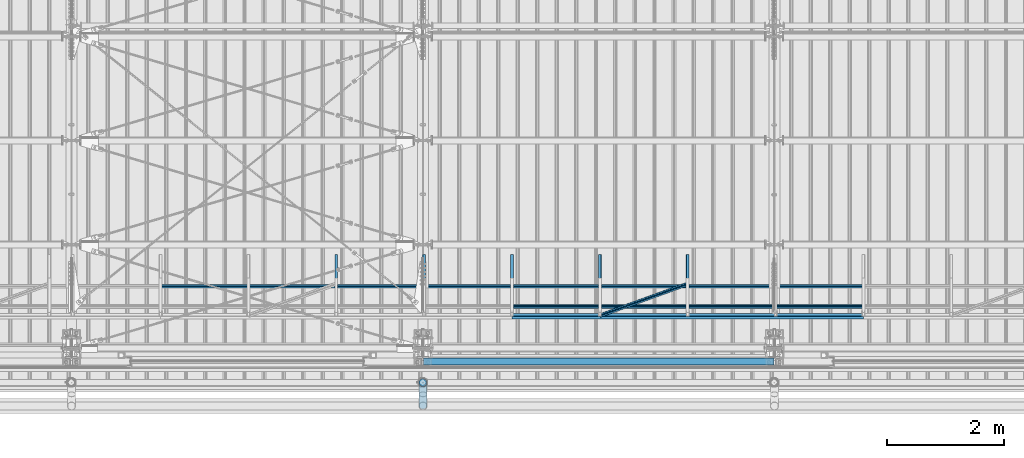
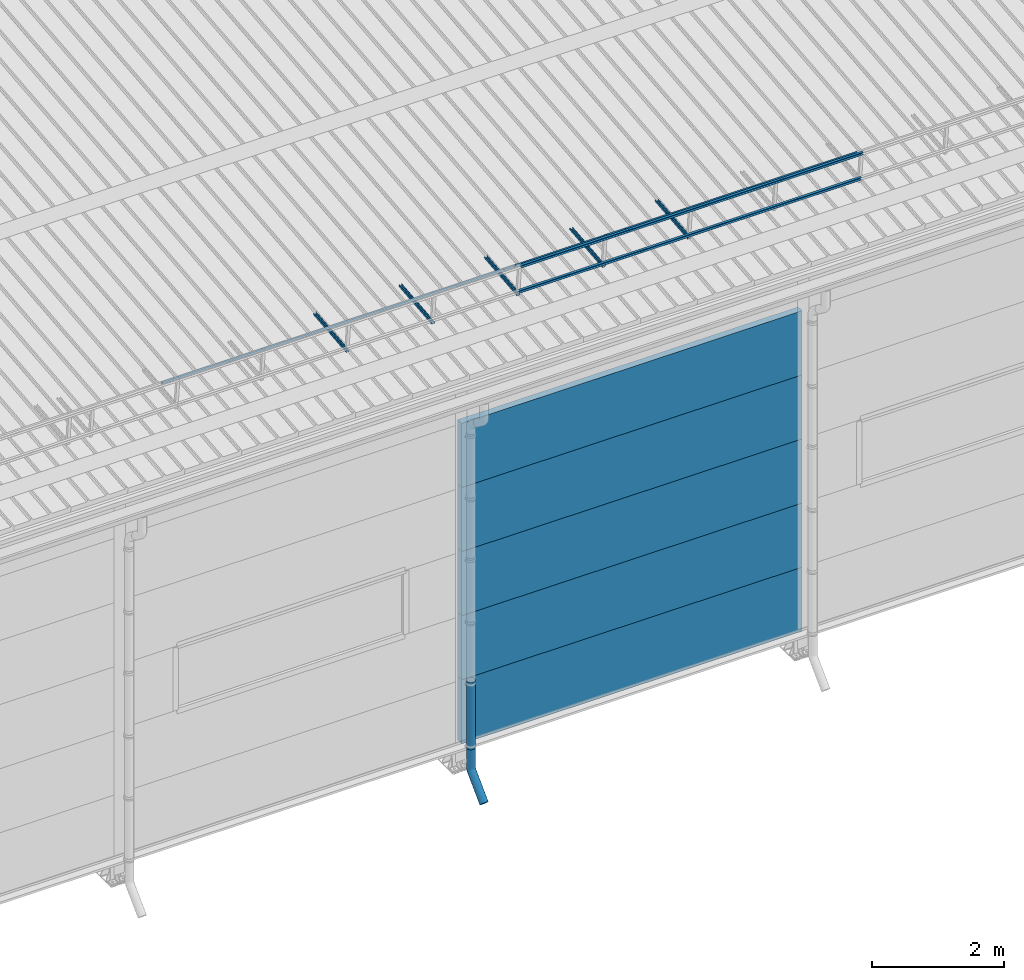
# One storey, part 37 of 709: 18 beams, 18 elements without a shape of their own.
"""IFC4 building model written with IfcOpenShell, lengths in millimetres."""

import ifcopenshell
import ifcopenshell.guid

model = None  # the IFC model being written
_history = None  # IfcOwnerHistory: only IFC2X3 demands one
_inside = {}  # id of a spatial element -> (the spatial element, [elements in it])
_under = {}  # id of a project, library or spatial element -> (it, [spatial elements below it])
_declared = {}  # id of a project -> (the project, [libraries it declares])
_typed = {}  # id of a type object -> (the type object, [elements of that type])
_made_of = {}  # id of a material, layer set ... -> (it, [elements and type objects made of it])


def new_model(schema):
    """Start an empty IFC model of exactly this schema.

    Asked for "IFC4X3", IfcOpenShell would pick the latest addendum, in which some entities
    have other attributes; the version numbers below select the first issue.
    IFC2X3 requires an IfcOwnerHistory on every rooted entity: one is made here for all.
    """
    global model, _history
    if schema == "IFC4X3":
        model = ifcopenshell.file(schema_version=(4, 3, 0, 0))
    else:
        model = ifcopenshell.file(schema=schema)
    _inside.clear()
    _under.clear()
    _declared.clear()
    _typed.clear()
    _made_of.clear()
    _history = None
    if model.schema == "IFC2X3":
        org = make("IfcOrganization", Name="unknown")
        user = make(
            "IfcPersonAndOrganization",
            ThePerson=make("IfcPerson", FamilyName="unknown"),
            TheOrganization=org,
        )
        app = make(
            "IfcApplication",
            ApplicationDeveloper=org,
            Version="unknown",
            ApplicationFullName="unknown",
            ApplicationIdentifier="unknown",
        )
        _history = make(
            "IfcOwnerHistory",
            OwningUser=user,
            OwningApplication=app,
            ChangeAction="ADDED",
            CreationDate=0,
        )
    return model


def make(cls, **values):
    """One entity of the class cls with the attributes given. An attribute that is None is left unset."""
    return model.create_entity(
        cls, **{name: value for name, value in values.items() if value is not None}
    )


def entity(cls, *values):
    """Any entity or typed value of the class cls, its attributes in the order of the schema. None: left unset."""
    e = model.create_entity(cls)
    for i, value in enumerate(values):
        if value is not None:
            e[i] = value
    return e


def rooted(cls, **values):
    """An entity with a GlobalId (a new one), such as an element, a storey or a relation."""
    return make(cls, GlobalId=ifcopenshell.guid.new(), OwnerHistory=_history, **values)


def si_unit(unit_type, name, prefix=None):
    """IfcSIUnit, for example si_unit("LENGTHUNIT", "METRE", prefix="MILLI")."""
    return make("IfcSIUnit", UnitType=unit_type, Prefix=prefix, Name=name)


def assignment(units):
    """IfcUnitAssignment: the units of a project."""
    return None if units is None else make("IfcUnitAssignment", Units=units)


def point(xyz):
    """IfcCartesianPoint."""
    return None if xyz is None else make("IfcCartesianPoint", Coordinates=xyz)


def direction(xyz):
    """IfcDirection."""
    return None if xyz is None else make("IfcDirection", DirectionRatios=xyz)


def frame(location, z_axis=None, x_axis=None):
    """IfcAxis2Placement3D, a coordinate frame: its origin and axes. An axis left out is left unset."""
    return make(
        "IfcAxis2Placement3D",
        Location=point(location),
        Axis=direction(z_axis),
        RefDirection=direction(x_axis),
    )


def origin_with_axes():
    """The frame at (0, 0, 0) with the z axis (0, 0, 1) and the x axis (1, 0, 0) written out."""
    return frame((0.0, 0.0, 0.0), z_axis=(0.0, 0.0, 1.0), x_axis=(1.0, 0.0, 0.0))


def place(relative_to, where):
    """IfcLocalPlacement: puts the frame where relative to a parent placement (None: the world)."""
    return make(
        "IfcLocalPlacement", PlacementRelTo=relative_to, RelativePlacement=where
    )


def context(
    kind, dimensions, precision=None, world=None, true_north=None, identifier=None
):
    """IfcGeometricRepresentationContext, for example the 3D "Model" context."""
    return make(
        "IfcGeometricRepresentationContext",
        ContextIdentifier=identifier,
        ContextType=kind,
        CoordinateSpaceDimension=dimensions,
        Precision=precision,
        WorldCoordinateSystem=world,
        TrueNorth=true_north,
    )


def subcontext(parent, identifier, kind, view, scale=None):
    """IfcGeometricRepresentationSubContext, for example "Body" below "Model"."""
    return make(
        "IfcGeometricRepresentationSubContext",
        ContextIdentifier=identifier,
        ContextType=kind,
        ParentContext=parent,
        TargetScale=scale,
        TargetView=view,
    )


def project(units=None, contexts=None):
    """IfcProject with its units and contexts."""
    return rooted(
        "IfcProject",
        Name="project",
        RepresentationContexts=contexts,
        UnitsInContext=assignment(units),
    )


def spatial(cls, under=None, at=None, **own):
    """A site, building, storey or space (cls), placed at a placement, below another one or the project."""
    s = rooted(cls, ObjectPlacement=at, **own)
    if under is not None:
        _under.setdefault(under.id(), (under, []))[1].append(s)
    return s


def point_list(points):
    """IfcCartesianPointList2D or 3D."""
    cls = (
        "IfcCartesianPointList2D" if len(points[0]) == 2 else "IfcCartesianPointList3D"
    )
    return make(cls, CoordList=points)


def line(*indices):
    """IfcLineIndex: a straight run through numbered points of an indexed curve."""
    return model.create_entity("IfcLineIndex", indices)


def indexed_curve(points, segments=None, self_intersect=None):
    """IfcIndexedPolyCurve: lines and arcs through numbered points (the first is 1)."""
    return make(
        "IfcIndexedPolyCurve",
        Points=point_list(points),
        Segments=segments,
        SelfIntersect=self_intersect,
    )


def outline(outer, holes=None, kind="AREA"):
    """IfcArbitraryClosedProfileDef: a profile drawn as a closed curve; with holes, ...WithVoids."""
    if holes is None:
        return make("IfcArbitraryClosedProfileDef", ProfileType=kind, OuterCurve=outer)
    return make(
        "IfcArbitraryProfileDefWithVoids",
        ProfileType=kind,
        OuterCurve=outer,
        InnerCurves=holes,
    )


def extrude(swept, where, along, depth):
    """IfcExtrudedAreaSolid: the profile swept, set in the frame where, extruded along a direction by depth."""
    return make(
        "IfcExtrudedAreaSolid",
        SweptArea=swept,
        Position=where,
        ExtrudedDirection=direction(along),
        Depth=depth,
    )


def shape(context_of_items, identifier, shape_type, items):
    """IfcShapeRepresentation: the items that make up one representation, for example the "Body"."""
    return make(
        "IfcShapeRepresentation",
        ContextOfItems=context_of_items,
        RepresentationIdentifier=identifier,
        RepresentationType=shape_type,
        Items=items,
    )


def material(Name=None, Category=None):
    """IfcMaterial."""
    return make("IfcMaterial", Name=Name, Category=Category)


def made_of(thing, what):
    """Note that an element or type object is made of a material, layer set ...; save() writes the relation."""
    if what is not None:
        _made_of.setdefault(what.id(), (what, []))[1].append(thing)
    return thing


def element(
    cls,
    number,
    at=None,
    inside=None,
    cuts=None,
    type_object=None,
    material=None,
    context=None,
    identifier="Body",
    shape_type=None,
    held_by="IfcProductDefinitionShape",
    body=None,
    shapes=None,
    **own,
):
    """One element of the class cls, such as IfcWall. Its Tag is "e" and its number.

    at: its placement. inside: the storey or other place that contains it. cuts: it is an
    opening in that element (IfcRelVoidsElement). A single representation is given by context,
    identifier, shape_type and body (its items); several are given by shapes. held_by: the class
    of the entity that holds the representations. save() writes the other relations.
    """
    e = rooted(cls, Tag="e%d" % number, ObjectPlacement=at, **own)
    if body is not None:
        shapes = [shape(context, identifier, shape_type, body)]
    if shapes is not None:
        e.Representation = make(held_by, Representations=shapes)
    if inside is not None:
        _inside.setdefault(inside.id(), (inside, []))[1].append(e)
    if cuts is not None:
        rooted(
            "IfcRelVoidsElement", RelatingBuildingElement=cuts, RelatedOpeningElement=e
        )
    if type_object is not None:
        _typed.setdefault(type_object.id(), (type_object, []))[1].append(e)
    return made_of(e, material)


def aggregate(whole, parts):
    """IfcRelAggregates: a whole, such as a stair, and the parts it consists of."""
    return rooted("IfcRelAggregates", RelatingObject=whole, RelatedObjects=parts)


def save(model, path):
    """Write the relations noted so far, then the file.

    IfcRelAggregates (storeys below a building ...), IfcRelContainedInSpatialStructure (elements
    in a storey), IfcRelDefinesByType, IfcRelAssociatesMaterial and IfcRelDeclares: one each for
    every whole, place, type object, material and project.
    """
    for whole, parts in _under.values():
        aggregate(whole, parts)
    for where, things in _inside.values():
        rooted(
            "IfcRelContainedInSpatialStructure",
            RelatedElements=things,
            RelatingStructure=where,
        )
    for kind, things in _typed.values():
        rooted("IfcRelDefinesByType", RelatedObjects=things, RelatingType=kind)
    for what, things in _made_of.values():
        rooted("IfcRelAssociatesMaterial", RelatedObjects=things, RelatingMaterial=what)
    for by, libraries in _declared.values():
        rooted("IfcRelDeclares", RelatingContext=by, RelatedDefinitions=libraries)
    model.write(path)


model = new_model("IFC4")

# Units and contexts
model_context = context("Model", 3, precision=0.2, world=origin_with_axes(), true_north=direction((0.0, 1.0)))
body_context = subcontext(model_context, "Body", "Model", "MODEL_VIEW")
ifc_project = project(units=[si_unit("LENGTHUNIT", "METRE", prefix="MILLI"), si_unit("AREAUNIT", "SQUARE_METRE"), si_unit("VOLUMEUNIT", "CUBIC_METRE"), si_unit("MASSUNIT", "GRAM", prefix="KILO"), si_unit("TIMEUNIT", "SECOND"), si_unit("PLANEANGLEUNIT", "RADIAN"), si_unit("SOLIDANGLEUNIT", "STERADIAN"), si_unit("THERMODYNAMICTEMPERATUREUNIT", "DEGREE_CELSIUS"), si_unit("LUMINOUSINTENSITYUNIT", "LUMEN")], contexts=[model_context])

# Site, building, storey
site_placement = place(None, origin_with_axes())
site = spatial("IfcSite", under=ifc_project, at=site_placement, CompositionType="ELEMENT")
building_placement = place(site_placement, origin_with_axes())
building = spatial("IfcBuilding", under=site, at=building_placement, Name="Undefined", CompositionType="ELEMENT")
storey_placement = place(building_placement, origin_with_axes())
storey = spatial("IfcBuildingStorey", under=building, at=storey_placement, Name="Undefined", CompositionType="ELEMENT", Elevation=0.0)

# Assembly, beam
assembly_1_placement = place(storey_placement, frame((8520.0, 768.92298, 7577.16191), z_axis=(0.0, -0.099503719, 0.9950371902), x_axis=(0.0, 0.9950371902, 0.099503719)))
assembly_1 = element("IfcElementAssembly", 1, at=assembly_1_placement, inside=storey)
ifc_material_1 = material(Name="Steel_Undefined", Category="STEEL")
beam_1_placement = place(assembly_1_placement, origin_with_axes())
beam_1 = element("IfcBeam", 2, at=beam_1_placement, material=ifc_material_1, ObjectType="601", context=body_context, shape_type="SolidModel", body=[
    extrude(outline(indexed_curve([(-20.0, -25.0), (20.0, -25.0), (20.0, -22.5), (-17.5, -22.5), (-17.5, 22.5), (20.0, 22.5), (20.0, 25.0), (-20.0, 25.0)], segments=[line(1, 2, 3, 4, 5, 6, 7, 8, 1)])), frame((0.0, 0.0, 0.0), z_axis=(-1.0, 0.0, 0.0), x_axis=(0.0, 0.0, 1.0)), (0.0, 0.0, -1.0), 1000.0),
])
aggregate(assembly_1, [beam_1])

assembly_2_placement = place(storey_placement, frame((10020.0, 768.92298, 7577.16191), z_axis=(0.0, -0.099503719, 0.9950371902), x_axis=(0.0, 0.9950371902, 0.099503719)))
assembly_2 = element("IfcElementAssembly", 3, at=assembly_2_placement, inside=storey)
beam_2_placement = place(assembly_2_placement, origin_with_axes())
beam_2 = element("IfcBeam", 4, at=beam_2_placement, material=ifc_material_1, ObjectType="601", context=body_context, shape_type="SolidModel", body=[
    extrude(outline(indexed_curve([(-20.0, -25.0), (20.0, -25.0), (20.0, -22.5), (-17.5, -22.5), (-17.5, 22.5), (20.0, 22.5), (20.0, 25.0), (-20.0, 25.0)], segments=[line(1, 2, 3, 4, 5, 6, 7, 8, 1)])), frame((0.0, 0.0, 0.0), z_axis=(-1.0, 0.0, 0.0), x_axis=(0.0, 0.0, 1.0)), (0.0, 0.0, -1.0), 1000.0),
])
aggregate(assembly_2, [beam_2])

assembly_3_placement = place(storey_placement, frame((5520.0, 1225.80867, 7759.0901), z_axis=(0.0, 0.6332377902, 0.7739572992), x_axis=(1.0, 0.0, 0.0)))
assembly_3 = element("IfcElementAssembly", 5, at=assembly_3_placement, inside=storey)
beam_3_placement = place(assembly_3_placement, origin_with_axes())
beam_3 = element("IfcBeam", 6, at=beam_3_placement, material=ifc_material_1, ObjectType="606", context=body_context, shape_type="SolidModel", body=[
    extrude(outline(indexed_curve([(-20.0, -25.0), (20.0, -25.0), (20.0, -22.5), (-17.5, -22.5), (-17.5, 22.5), (20.0, 22.5), (20.0, 25.0), (-20.0, 25.0)], segments=[line(1, 2, 3, 4, 5, 6, 7, 8, 1)])), frame((0.0, 0.0, 0.0), z_axis=(-1.0, 0.0, 0.0), x_axis=(0.0, 0.0, 1.0)), (0.0, 0.0, -1.0), 6000.0),
])
aggregate(assembly_3, [beam_3])

assembly_4_placement = place(storey_placement, frame((11520.0, 768.92298, 7577.16191), z_axis=(0.0, -0.099503719, 0.9950371902), x_axis=(0.0, 0.9950371902, 0.099503719)))
assembly_4 = element("IfcElementAssembly", 7, at=assembly_4_placement, inside=storey)
beam_4_placement = place(assembly_4_placement, origin_with_axes())
beam_4 = element("IfcBeam", 8, at=beam_4_placement, material=ifc_material_1, ObjectType="601", context=body_context, shape_type="SolidModel", body=[
    extrude(outline(indexed_curve([(-20.0, -25.0), (20.0, -25.0), (20.0, -22.5), (-17.5, -22.5), (-17.5, 22.5), (20.0, 22.5), (20.0, 25.0), (-20.0, 25.0)], segments=[line(1, 2, 3, 4, 5, 6, 7, 8, 1)])), frame((0.0, 0.0, 0.0), z_axis=(-1.0, 0.0, 0.0), x_axis=(0.0, 0.0, 1.0)), (0.0, 0.0, -1.0), 1000.0),
])
aggregate(assembly_4, [beam_4])

assembly_5_placement = place(storey_placement, frame((13020.0, 768.92298, 7577.16191), z_axis=(0.0, -0.099503719, 0.9950371902), x_axis=(0.0, 0.9950371902, 0.099503719)))
assembly_5 = element("IfcElementAssembly", 9, at=assembly_5_placement, inside=storey)
beam_5_placement = place(assembly_5_placement, origin_with_axes())
beam_5 = element("IfcBeam", 10, at=beam_5_placement, material=ifc_material_1, ObjectType="601", context=body_context, shape_type="SolidModel", body=[
    extrude(outline(indexed_curve([(-20.0, -25.0), (20.0, -25.0), (20.0, -22.5), (-17.5, -22.5), (-17.5, 22.5), (20.0, 22.5), (20.0, 25.0), (-20.0, 25.0)], segments=[line(1, 2, 3, 4, 5, 6, 7, 8, 1)])), frame((0.0, 0.0, 0.0), z_axis=(-1.0, 0.0, 0.0), x_axis=(0.0, 0.0, 1.0)), (0.0, 0.0, -1.0), 1000.0),
])
aggregate(assembly_5, [beam_5])

assembly_6_placement = place(storey_placement, frame((14520.0, 768.92298, 7577.16191), z_axis=(0.0, -0.099503719, 0.9950371902), x_axis=(0.0, 0.9950371902, 0.099503719)))
assembly_6 = element("IfcElementAssembly", 11, at=assembly_6_placement, inside=storey)
beam_6_placement = place(assembly_6_placement, origin_with_axes())
beam_6 = element("IfcBeam", 12, at=beam_6_placement, material=ifc_material_1, ObjectType="601", context=body_context, shape_type="SolidModel", body=[
    extrude(outline(indexed_curve([(-20.0, -25.0), (20.0, -25.0), (20.0, -22.5), (-17.5, -22.5), (-17.5, 22.5), (20.0, 22.5), (20.0, 25.0), (-20.0, 25.0)], segments=[line(1, 2, 3, 4, 5, 6, 7, 8, 1)])), frame((0.0, 0.0, 0.0), z_axis=(-1.0, 0.0, 0.0), x_axis=(0.0, 0.0, 1.0)), (0.0, 0.0, -1.0), 1000.0),
])
aggregate(assembly_6, [beam_6])

assembly_7_placement = place(storey_placement, frame((11520.0, 691.31008, 8152.29341), z_axis=(0.0, -0.9950371902, -0.099503719), x_axis=(1.0, 0.0, 0.0)))
assembly_7 = element("IfcElementAssembly", 13, at=assembly_7_placement, inside=storey)
beam_7_placement = place(assembly_7_placement, origin_with_axes())
beam_7 = element("IfcBeam", 14, at=beam_7_placement, material=ifc_material_1, ObjectType="606", context=body_context, shape_type="SolidModel", body=[
    extrude(outline(indexed_curve([(-20.0, -25.0), (20.0, -25.0), (20.0, -22.5), (-17.5, -22.5), (-17.5, 22.5), (20.0, 22.5), (20.0, 25.0), (-20.0, 25.0)], segments=[line(1, 2, 3, 4, 5, 6, 7, 8, 1)])), frame((0.0, 0.0, 0.0), z_axis=(-1.0, 0.0, 0.0), x_axis=(0.0, 0.0, 1.0)), (0.0, 0.0, -1.0), 6000.0),
])
aggregate(assembly_7, [beam_7])

assembly_8_placement = place(storey_placement, frame((11520.0, 741.06194, 7654.77481), z_axis=(0.0, -0.9950371902, -0.099503719), x_axis=(1.0, 0.0, 0.0)))
assembly_8 = element("IfcElementAssembly", 15, at=assembly_8_placement, inside=storey)
beam_8_placement = place(assembly_8_placement, origin_with_axes())
beam_8 = element("IfcBeam", 16, at=beam_8_placement, material=ifc_material_1, ObjectType="606", context=body_context, shape_type="SolidModel", body=[
    extrude(outline(indexed_curve([(-20.0, -25.0), (20.0, -25.0), (20.0, -22.5), (-17.5, -22.5), (-17.5, 22.5), (20.0, 22.5), (20.0, 25.0), (-20.0, 25.0)], segments=[line(1, 2, 3, 4, 5, 6, 7, 8, 1)])), frame((0.0, 0.0, 0.0), z_axis=(-1.0, 0.0, 0.0), x_axis=(0.0, 0.0, 1.0)), (0.0, 0.0, -1.0), 6000.0),
])
aggregate(assembly_8, [beam_8])

assembly_9_placement = place(storey_placement, frame((11520.0, 878.66704, 8043.11507), z_axis=(0.0, 0.6332377902, 0.7739572992), x_axis=(1.0, 0.0, 0.0)))
assembly_9 = element("IfcElementAssembly", 17, at=assembly_9_placement, inside=storey)
beam_9_placement = place(assembly_9_placement, origin_with_axes())
beam_9 = element("IfcBeam", 18, at=beam_9_placement, material=ifc_material_1, ObjectType="606", context=body_context, shape_type="SolidModel", body=[
    extrude(outline(indexed_curve([(-20.0, -25.0), (20.0, -25.0), (20.0, -22.5), (-17.5, -22.5), (-17.5, 22.5), (20.0, 22.5), (20.0, 25.0), (-20.0, 25.0)], segments=[line(1, 2, 3, 4, 5, 6, 7, 8, 1)])), frame((0.0, 0.0, 0.0), z_axis=(-1.0, 0.0, 0.0), x_axis=(0.0, 0.0, 1.0)), (0.0, 0.0, -1.0), 6000.0),
])
aggregate(assembly_9, [beam_9])

assembly_10_placement = place(storey_placement, frame((11520.0, 1225.80867, 7759.0901), z_axis=(0.0, 0.6332377902, 0.7739572992), x_axis=(1.0, 0.0, 0.0)))
assembly_10 = element("IfcElementAssembly", 19, at=assembly_10_placement, inside=storey)
beam_10_placement = place(assembly_10_placement, origin_with_axes())
beam_10 = element("IfcBeam", 20, at=beam_10_placement, material=ifc_material_1, ObjectType="606", context=body_context, shape_type="SolidModel", body=[
    extrude(outline(indexed_curve([(-20.0, -25.0), (20.0, -25.0), (20.0, -22.5), (-17.5, -22.5), (-17.5, 22.5), (20.0, 22.5), (20.0, 25.0), (-20.0, 25.0)], segments=[line(1, 2, 3, 4, 5, 6, 7, 8, 1)])), frame((0.0, 0.0, 0.0), z_axis=(-1.0, 0.0, 0.0), x_axis=(0.0, 0.0, 1.0)), (0.0, 0.0, -1.0), 6000.0),
])
aggregate(assembly_10, [beam_10])

assembly_11_placement = place(storey_placement, frame((13020.0, 723.87558, 8169.76263), z_axis=(0.0, 0.6332377902, 0.7739572992), x_axis=(0.9061831398, 0.3272952929, -0.2677870579)))
assembly_11 = element("IfcElementAssembly", 21, at=assembly_11_placement, inside=storey)
beam_11_placement = place(assembly_11_placement, origin_with_axes())
beam_11 = element("IfcBeam", 22, at=beam_11_placement, material=ifc_material_1, ObjectType="605", context=body_context, shape_type="SolidModel", body=[
    extrude(outline(indexed_curve([(-20.0, -25.0), (20.0, -25.0), (20.0, -22.5), (-17.5, -22.5), (-17.5, 22.5), (20.0, 22.5), (20.0, 25.0), (-20.0, 25.0)], segments=[line(1, 2, 3, 4, 5, 6, 7, 8, 1)])), frame((0.0, 0.0, 0.0), z_axis=(-1.0, 0.0, 0.0), x_axis=(0.0, 0.0, 1.0)), (0.0, 0.0, -1.0), 1655.29454),
])
aggregate(assembly_11, [beam_11])

assembly_12_placement = place(storey_placement, frame((10010.0, -60.0, 895.0), z_axis=(0.0, 0.0, -1.0), x_axis=(1.0, 0.0, 0.0)))
assembly_12 = element("IfcElementAssembly", 23, at=assembly_12_placement, inside=storey)
ifc_material_2 = material(Name="Insulation", Category="Insulation")
beam_12_placement = place(assembly_12_placement, origin_with_axes())
beam_12 = element("IfcBeam", 24, at=beam_12_placement, material=ifc_material_2, ObjectType="P-107", context=body_context, shape_type="SolidModel", body=[
    extrude(outline(indexed_curve([(-595.0, -60.0), (595.0, -60.0), (595.0, 60.0), (-595.0, 60.0)], segments=[line(1, 2, 3, 4, 1)])), frame((0.0, 0.0, 0.0), z_axis=(-1.0, 0.0, 0.0), x_axis=(0.0, 0.0, 1.0)), (0.0, 0.0, -1.0), 5980.0),
])
aggregate(assembly_12, [beam_12])

assembly_13_placement = place(storey_placement, frame((10010.0, -60.0, 2085.0), z_axis=(0.0, 0.0, -1.0), x_axis=(1.0, 0.0, 0.0)))
assembly_13 = element("IfcElementAssembly", 25, at=assembly_13_placement, inside=storey)
beam_13_placement = place(assembly_13_placement, origin_with_axes())
beam_13 = element("IfcBeam", 26, at=beam_13_placement, material=ifc_material_2, ObjectType="P-107", context=body_context, shape_type="SolidModel", body=[
    extrude(outline(indexed_curve([(-595.0, -60.0), (595.0, -60.0), (595.0, 60.0), (-595.0, 60.0)], segments=[line(1, 2, 3, 4, 1)])), frame((0.0, 0.0, 0.0), z_axis=(-1.0, 0.0, 0.0), x_axis=(0.0, 0.0, 1.0)), (0.0, 0.0, -1.0), 5980.0),
])
aggregate(assembly_13, [beam_13])

assembly_14_placement = place(storey_placement, frame((10010.0, -60.0, 3275.0), z_axis=(0.0, 0.0, -1.0), x_axis=(1.0, 0.0, 0.0)))
assembly_14 = element("IfcElementAssembly", 27, at=assembly_14_placement, inside=storey)
beam_14_placement = place(assembly_14_placement, origin_with_axes())
beam_14 = element("IfcBeam", 28, at=beam_14_placement, material=ifc_material_2, ObjectType="P-107", context=body_context, shape_type="SolidModel", body=[
    extrude(outline(indexed_curve([(-595.0, -60.0), (595.0, -60.0), (595.0, 60.0), (-595.0, 60.0)], segments=[line(1, 2, 3, 4, 1)])), frame((0.0, 0.0, 0.0), z_axis=(-1.0, 0.0, 0.0), x_axis=(0.0, 0.0, 1.0)), (0.0, 0.0, -1.0), 5980.0),
])
aggregate(assembly_14, [beam_14])

assembly_15_placement = place(storey_placement, frame((10010.0, -60.0, 4465.0), z_axis=(0.0, 0.0, -1.0), x_axis=(1.0, 0.0, 0.0)))
assembly_15 = element("IfcElementAssembly", 29, at=assembly_15_placement, inside=storey)
beam_15_placement = place(assembly_15_placement, origin_with_axes())
beam_15 = element("IfcBeam", 30, at=beam_15_placement, material=ifc_material_2, ObjectType="P-107", context=body_context, shape_type="SolidModel", body=[
    extrude(outline(indexed_curve([(-595.0, -60.0), (595.0, -60.0), (595.0, 60.0), (-595.0, 60.0)], segments=[line(1, 2, 3, 4, 1)])), frame((0.0, 0.0, 0.0), z_axis=(-1.0, 0.0, 0.0), x_axis=(0.0, 0.0, 1.0)), (0.0, 0.0, -1.0), 5980.0),
])
aggregate(assembly_15, [beam_15])

assembly_16_placement = place(storey_placement, frame((10010.0, -60.0, 5655.0), z_axis=(0.0, 0.0, -1.0), x_axis=(1.0, 0.0, 0.0)))
assembly_16 = element("IfcElementAssembly", 31, at=assembly_16_placement, inside=storey)
beam_16_placement = place(assembly_16_placement, origin_with_axes())
beam_16 = element("IfcBeam", 32, at=beam_16_placement, material=ifc_material_2, ObjectType="P-107", context=body_context, shape_type="SolidModel", body=[
    extrude(outline(indexed_curve([(-595.0, -60.0), (595.0, -60.0), (595.0, 60.0), (-595.0, 60.0)], segments=[line(1, 2, 3, 4, 1)])), frame((0.0, 0.0, 0.0), z_axis=(-1.0, 0.0, 0.0), x_axis=(0.0, 0.0, 1.0)), (0.0, 0.0, -1.0), 5980.0),
])
aggregate(assembly_16, [beam_16])

assembly_17_placement = place(storey_placement, frame((10000.0, -420.0, 1676.92297), z_axis=(0.0, 1.0, 0.0), x_axis=(0.0, 0.0, -1.0)))
assembly_17 = element("IfcElementAssembly", 33, at=assembly_17_placement, inside=storey)
beam_17_placement = place(assembly_17_placement, origin_with_axes())
beam_17 = element("IfcBeam", 34, at=beam_17_placement, material=ifc_material_1, ObjectType="614", context=body_context, shape_type="SolidModel", body=[
    extrude(outline(indexed_curve([(70.0, 0.0), (69.61653, 7.31699), (68.47033, 14.55382), (66.57396, 21.63119), (63.94818, 28.47157), (60.62178, 35.0), (56.63119, 41.14497), (52.02014, 46.83914), (46.83914, 52.02014), (41.14497, 56.63119), (35.0, 60.62178), (28.47157, 63.94818), (21.63119, 66.57396), (14.55382, 68.47033), (7.31699, 69.61653), (0.0, 70.0), (-7.31699, 69.61653), (-14.55382, 68.47033), (-21.63119, 66.57396), (-28.47157, 63.94818), (-35.0, 60.62178), (-41.14497, 56.63119), (-46.83914, 52.02014), (-52.02014, 46.83914), (-56.63119, 41.14497), (-60.62178, 35.0), (-63.94818, 28.47157), (-66.57396, 21.63119), (-68.47033, 14.55382), (-69.61653, 7.31699), (-70.0, 0.0), (-69.61653, -7.31699), (-68.47033, -14.55382), (-66.57396, -21.63119), (-63.94818, -28.47157), (-60.62178, -35.0), (-56.63119, -41.14497), (-52.02014, -46.83914), (-46.83914, -52.02014), (-41.14497, -56.63119), (-35.0, -60.62178), (-28.47157, -63.94818), (-21.63119, -66.57396), (-14.55382, -68.47033), (-7.31699, -69.61653), (0.0, -70.0), (7.31699, -69.61653), (14.55382, -68.47033), (21.63119, -66.57396), (28.47157, -63.94818), (35.0, -60.62178), (41.14497, -56.63119), (46.83914, -52.02014), (52.02014, -46.83914), (56.63119, -41.14497), (60.62178, -35.0), (63.94818, -28.47157), (66.57396, -21.63119), (68.47033, -14.55382), (69.61653, -7.31699)], segments=[line(1, 2, 3, 4, 5, 6, 7, 8, 9, 10, 11, 12, 13, 14, 15, 16, 17, 18, 19, 20, 21, 22, 23, 24, 25, 26, 27, 28, 29, 30, 31, 32, 33, 34, 35, 36, 37, 38, 39, 40, 41, 42, 43, 44, 45, 46, 47, 48, 49, 50, 51, 52, 53, 54, 55, 56, 57, 58, 59, 60, 1)]), holes=[indexed_curve([(65.0, 0.0), (64.64392, -6.79435), (63.57959, -13.51426), (61.81867, -20.0861), (59.38045, -26.43788), (56.29165, -32.5), (52.5861, -38.20604), (48.30441, -43.49349), (43.49349, -48.30441), (38.20604, -52.5861), (32.5, -56.29165), (26.43788, -59.38045), (20.0861, -61.81867), (13.51426, -63.57959), (6.79435, -64.64392), (0.0, -65.0), (-6.79435, -64.64392), (-13.51426, -63.57959), (-20.0861, -61.81867), (-26.43788, -59.38045), (-32.5, -56.29165), (-38.20604, -52.5861), (-43.49349, -48.30441), (-48.30441, -43.49349), (-52.5861, -38.20604), (-56.29165, -32.5), (-59.38045, -26.43788), (-61.81867, -20.0861), (-63.57959, -13.51426), (-64.64392, -6.79435), (-65.0, 0.0), (-64.64392, 6.79435), (-63.57959, 13.51426), (-61.81867, 20.0861), (-59.38045, 26.43788), (-56.29165, 32.5), (-52.5861, 38.20604), (-48.30441, 43.49349), (-43.49349, 48.30441), (-38.20604, 52.5861), (-32.5, 56.29165), (-26.43788, 59.38045), (-20.0861, 61.81867), (-13.51426, 63.57959), (-6.79435, 64.64392), (0.0, 65.0), (6.79435, 64.64392), (13.51426, 63.57959), (20.0861, 61.81867), (26.43788, 59.38045), (32.5, 56.29165), (38.20604, 52.5861), (43.49349, 48.30441), (48.30441, 43.49349), (52.5861, 38.20604), (56.29165, 32.5), (59.38045, 26.43788), (61.81867, 20.0861), (63.57959, 13.51426), (64.64392, 6.79435)], segments=[line(1, 2, 3, 4, 5, 6, 7, 8, 9, 10, 11, 12, 13, 14, 15, 16, 17, 18, 19, 20, 21, 22, 23, 24, 25, 26, 27, 28, 29, 30, 31, 32, 33, 34, 35, 36, 37, 38, 39, 40, 41, 42, 43, 44, 45, 46, 47, 48, 49, 50, 51, 52, 53, 54, 55, 56, 57, 58, 59, 60, 1)])]), frame((0.0, 0.0, 0.0), z_axis=(-1.0, 0.0, 0.0), x_axis=(0.0, 0.0, 1.0)), (0.0, 0.0, -1.0), 1250.0),
])
aggregate(assembly_17, [beam_17])

assembly_18_placement = place(storey_placement, frame((10000.0, -420.0, 526.92297), z_axis=(-1.0, 0.0, 0.0), x_axis=(0.0, 0.0, -1.0)))
assembly_18 = element("IfcElementAssembly", 35, at=assembly_18_placement, inside=storey)
beam_18_placement = place(assembly_18_placement, origin_with_axes())
beam_18 = element("IfcBeam", 36, at=beam_18_placement, material=ifc_material_1, ObjectType="617", context=body_context, shape_type="SolidModel", body=[
    entity("IfcSweptDiskSolid", entity("IfcIndexedPolyCurve", entity("IfcCartesianPointList3D", [[0.0, 0.0, 0.0], [448.2233, 0.0, 0.0], [496.05873, 9.51506, 0.0], [536.61165, 36.61165, 0.0], [900.0, 400.0, 0.0]]), [entity("IfcLineIndex", [1, 2]), entity("IfcArcIndex", [2, 3, 4]), entity("IfcLineIndex", [4, 5])]), 70.0, 65.0),
])
aggregate(assembly_18, [beam_18])

save(model, "model.ifc")
